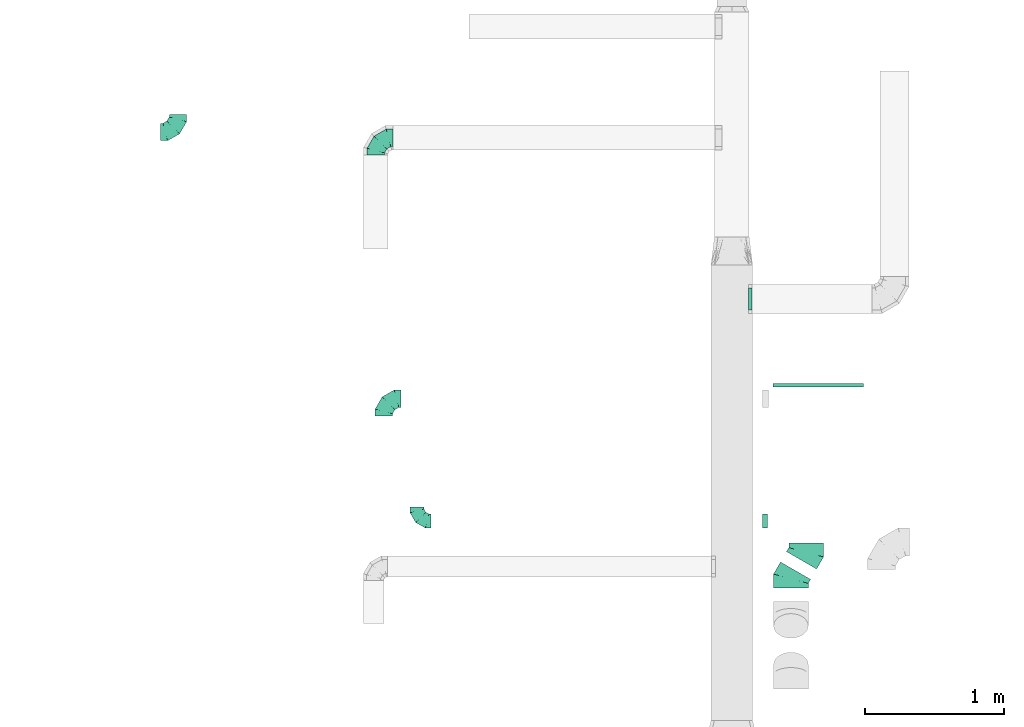
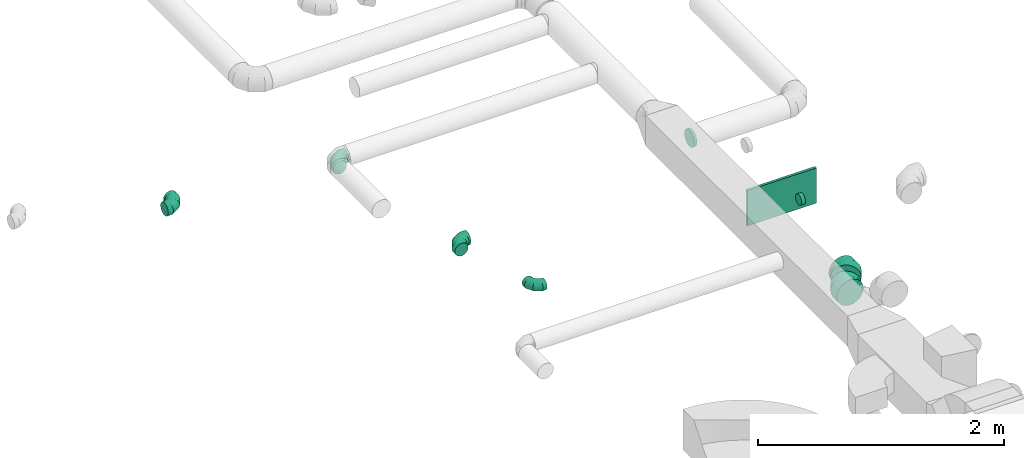
# One storey, part 31 of 62: 9 flow fittings.
"""IFC2X3 building model written with IfcOpenShell, lengths in millimetres."""

from ifc_helpers import new_model, entity, si_unit, converted_unit, derived_unit, direction, frame, origin, origin_2d_with_axis, place, context, subcontext, project, spatial, rectangle, extrude, faceted_brep, source, transform, mapped, material, type_object, type_shapes, element, save


model = new_model("IFC2X3")

# Units and contexts
model_context = context("Model", 3, precision=0.01, world=origin(), true_north=direction((6.12303176911189e-17, 1.0)))
body_context = subcontext(model_context, "Body", "Model", "MODEL_VIEW")
ifc_project = project(units=[si_unit("LENGTHUNIT", "METRE", prefix="MILLI"), si_unit("AREAUNIT", "SQUARE_METRE"), si_unit("VOLUMEUNIT", "CUBIC_METRE"), converted_unit("PLANEANGLEUNIT", "DEGREE", entity("IfcRatioMeasure", 0.0174532925199433), si_unit("PLANEANGLEUNIT", "RADIAN"), dimensions=[0, 0, 0, 0, 0, 0, 0]), si_unit("MASSUNIT", "GRAM", prefix="KILO"), derived_unit("MASSDENSITYUNIT", [(si_unit("MASSUNIT", "GRAM", prefix="KILO"), 1), (si_unit("LENGTHUNIT", "METRE"), -3)]), derived_unit("MOMENTOFINERTIAUNIT", [(si_unit("LENGTHUNIT", "METRE"), 4)]), si_unit("TIMEUNIT", "SECOND"), si_unit("FREQUENCYUNIT", "HERTZ"), si_unit("THERMODYNAMICTEMPERATUREUNIT", "DEGREE_CELSIUS"), derived_unit("THERMALTRANSMITTANCEUNIT", [(si_unit("MASSUNIT", "GRAM", prefix="KILO"), 1), (si_unit("THERMODYNAMICTEMPERATUREUNIT", "KELVIN"), -1), (si_unit("TIMEUNIT", "SECOND"), -3)]), derived_unit("VOLUMETRICFLOWRATEUNIT", [(si_unit("LENGTHUNIT", "METRE"), 3), (si_unit("TIMEUNIT", "SECOND"), -1)]), derived_unit("MASSFLOWRATEUNIT", [(si_unit("MASSUNIT", "GRAM", prefix="KILO"), 1), (si_unit("TIMEUNIT", "SECOND"), -1)]), derived_unit("ROTATIONALFREQUENCYUNIT", [(si_unit("TIMEUNIT", "SECOND"), -1)]), si_unit("ELECTRICCURRENTUNIT", "AMPERE"), si_unit("ELECTRICVOLTAGEUNIT", "VOLT"), si_unit("POWERUNIT", "WATT"), si_unit("FORCEUNIT", "NEWTON", prefix="KILO"), si_unit("ILLUMINANCEUNIT", "LUX"), si_unit("LUMINOUSFLUXUNIT", "LUMEN"), si_unit("LUMINOUSINTENSITYUNIT", "CANDELA"), derived_unit("USERDEFINED", [(si_unit("MASSUNIT", "GRAM", prefix="KILO"), -1), (si_unit("LENGTHUNIT", "METRE"), -2), (si_unit("TIMEUNIT", "SECOND"), 3), (si_unit("LUMINOUSFLUXUNIT", "LUMEN"), 1)]), derived_unit("LINEARVELOCITYUNIT", [(si_unit("LENGTHUNIT", "METRE"), 1), (si_unit("TIMEUNIT", "SECOND"), -1)]), si_unit("PRESSUREUNIT", "PASCAL"), derived_unit("USERDEFINED", [(si_unit("LENGTHUNIT", "METRE"), -2), (si_unit("MASSUNIT", "GRAM", prefix="KILO"), 1), (si_unit("TIMEUNIT", "SECOND"), -2)]), derived_unit("LINEARFORCEUNIT", [(si_unit("MASSUNIT", "GRAM", prefix="KILO"), 1), (si_unit("LENGTHUNIT", "METRE"), 1), (si_unit("TIMEUNIT", "SECOND"), -2), (si_unit("LENGTHUNIT", "METRE"), -1)]), derived_unit("PLANARFORCEUNIT", [(si_unit("MASSUNIT", "GRAM", prefix="KILO"), 1), (si_unit("LENGTHUNIT", "METRE"), 1), (si_unit("TIMEUNIT", "SECOND"), -2), (si_unit("LENGTHUNIT", "METRE"), -2)])], contexts=[model_context])

# Site, building, storey
site_placement = place(None, origin())
site = spatial("IfcSite", under=ifc_project, at=site_placement, CompositionType="ELEMENT")
building_placement = place(site_placement, origin())
building = spatial("IfcBuilding", under=site, at=building_placement, CompositionType="ELEMENT")
storey_placement = place(building_placement, frame((0.0, 0.0, 24000.0)))
storey = spatial("IfcBuildingStorey", under=building, at=storey_placement, CompositionType="ELEMENT", Elevation=24000.0)

# Flow fittings
ifc_material = material()
duct_fitting_type_1 = type_object("IfcDuctFittingType", PredefinedType="NOTDEFINED", material=ifc_material)
shared_shape_1 = source(origin(), body_context, "Body", "SweptSolid", [
    extrude(rectangle(XDim=24.9999999999999, YDim=650.0, at=origin_2d_with_axis()), frame((12.5, 0.0, -175.0)), (0.0, 0.0, 1.0), 350.0),
])
type_shapes(duct_fitting_type_1, [shared_shape_1])
flow_fitting_1_placement = place(storey_placement, frame((40717.62, 13747.53, 2775.0), z_axis=(0.0, 0.0, 1.0), x_axis=(0.0, 1.0, 0.0)))
element("IfcFlowFitting", 1, at=flow_fitting_1_placement, inside=storey, type_object=duct_fitting_type_1, material=ifc_material, context=body_context, shape_type="MappedRepresentation", body=[
    mapped(shared_shape_1, transform((0.0, 0.0, 0.0), scale=1.0)),
])
duct_fitting_type_2 = type_object("IfcDuctFittingType", PredefinedType="NOTDEFINED", material=ifc_material)
shared_shape_2 = source(origin(), body_context, "Body", "Brep", [
    faceted_brep([(-100.0, 0.0, -50.0), (-100.0, -12.94, -48.3), (-100.0, -25.0, -43.3), (-100.0, -35.36, -35.36), (-100.0, -43.3, -25.0), (-100.0, -48.3, -12.94), (-100.0, -50.0, 0.0), (-100.0, -48.3, 12.94), (-100.0, -43.3, 25.0), (-100.0, -35.36, 35.36), (-100.0, -25.0, 43.3), (-100.0, -12.94, 48.3), (-100.0, 0.0, 50.0), (-100.0, 12.94, 48.3), (-100.0, 25.0, 43.3), (-100.0, 35.36, 35.36), (-100.0, 43.3, 25.0), (-100.0, 48.3, 12.94), (-100.0, 50.0, 0.0), (-100.0, 48.3, -12.94), (-100.0, 43.3, -25.0), (-100.0, 35.36, -35.36), (-100.0, 25.0, -43.3), (-100.0, 12.94, -48.3), (-76.67, 12.94, 48.3), (-79.9, 25.0, 43.3), (-73.21, 0.0, 50.0), (-82.68, 35.36, 35.36), (-86.15, 48.3, 12.94), (-86.6, 50.0, 0.0), (-84.81, 43.3, 25.0), (-84.81, 43.3, -25.0), (-82.68, 35.36, -35.36), (-86.15, 48.3, -12.94), (-76.67, 12.94, -48.3), (-73.21, 0.0, -50.0), (-79.9, 25.0, -43.3), (-69.74, -12.94, -48.3), (-66.51, -25.0, -43.3), (-63.73, -35.36, -35.36), (-61.6, -43.3, -25.0), (-60.26, -48.3, -12.94), (-59.81, -50.0, 0.0), (-60.26, -48.3, 12.94), (-61.6, -43.3, 25.0), (-63.73, -35.36, 35.36), (-66.51, -25.0, 43.3), (-69.74, -12.94, 48.3), (-36.27, 36.27, 48.3), (-45.1, 45.1, 43.3), (-26.79, 26.79, 50.0), (-52.68, 52.68, 35.36), (-58.49, 58.49, 25.0), (-62.15, 62.15, 12.94), (-63.4, 63.4, 0.0), (-62.15, 62.15, -12.94), (-58.49, 58.49, -25.0), (-52.68, 52.68, -35.36), (-36.27, 36.27, -48.3), (-26.79, 26.79, -50.0), (-45.1, 45.1, -43.3), (-17.32, 17.32, -48.3), (-8.49, 8.49, -43.3), (-0.91, 0.91, -35.36), (4.9, -4.9, -25.0), (8.56, -8.56, -12.94), (9.81, -9.81, 0.0), (8.56, -8.56, 12.94), (4.9, -4.9, 25.0), (-0.91, 0.91, 35.36), (-8.49, 8.49, 43.3), (-17.32, 17.32, 48.3), (-12.94, 76.67, 48.3), (-25.0, 79.9, 43.3), (0.0, 73.21, 50.0), (-35.36, 82.68, 35.36), (-43.3, 84.81, 25.0), (-48.3, 86.15, 12.94), (-50.0, 86.6, 0.0), (-48.3, 86.15, -12.94), (-43.3, 84.81, -25.0), (-35.36, 82.68, -35.36), (-12.94, 76.67, -48.3), (0.0, 73.21, -50.0), (-25.0, 79.9, -43.3), (12.94, 69.74, -48.3), (25.0, 66.51, -43.3), (35.36, 63.73, -35.36), (43.3, 61.6, -25.0), (48.3, 60.26, -12.94), (50.0, 59.81, 0.0), (48.3, 60.26, 12.94), (43.3, 61.6, 25.0), (35.36, 63.73, 35.36), (25.0, 66.51, 43.3), (12.94, 69.74, 48.3), (-12.94, 100.0, -48.3), (-25.0, 100.0, -43.3), (-35.36, 100.0, -35.36), (-43.3, 100.0, -25.0), (-48.3, 100.0, -12.94), (-50.0, 100.0, 0.0), (-48.3, 100.0, 12.94), (-43.3, 100.0, 25.0), (-35.36, 100.0, 35.36), (-25.0, 100.0, 43.3), (-12.94, 100.0, 48.3), (0.0, 100.0, 50.0), (12.94, 100.0, 48.3), (25.0, 100.0, 43.3), (35.36, 100.0, 35.36), (43.3, 100.0, 25.0), (48.3, 100.0, 12.94), (50.0, 100.0, 0.0), (48.3, 100.0, -12.94), (43.3, 100.0, -25.0), (35.36, 100.0, -35.36), (25.0, 100.0, -43.3), (12.94, 100.0, -48.3), (0.0, 100.0, -50.0)], [[[0, 1, 2, 3, 4, 5, 6, 7, 8, 9, 10, 11, 12, 13, 14, 15, 16, 17, 18, 19, 20, 21, 22, 23]], [[24, 25, 14, 13]], [[26, 24, 13, 12]], [[14, 25, 27, 15]], [[28, 29, 18, 17]], [[30, 28, 17, 16]], [[15, 27, 30, 16]], [[20, 31, 32, 21]], [[33, 31, 20, 19]], [[18, 29, 33, 19]], [[34, 35, 0, 23]], [[36, 34, 23, 22]], [[32, 36, 22, 21]], [[2, 1, 37, 38]], [[3, 2, 38, 39]], [[0, 35, 37, 1]], [[5, 4, 40, 41]], [[6, 5, 41, 42]], [[3, 39, 40, 4]], [[6, 42, 43, 7]], [[7, 43, 44, 8]], [[8, 44, 45, 9]], [[10, 46, 47, 11]], [[11, 47, 26, 12]], [[10, 9, 45, 46]], [[48, 49, 25, 24]], [[50, 48, 24, 26]], [[27, 25, 49, 51]], [[52, 53, 28, 30]], [[51, 52, 30, 27]], [[29, 28, 53, 54]], [[55, 56, 31, 33]], [[54, 55, 33, 29]], [[57, 32, 31, 56]], [[58, 59, 35, 34]], [[60, 58, 34, 36]], [[57, 60, 36, 32]], [[37, 35, 59, 61]], [[38, 37, 61, 62]], [[39, 38, 62, 63]], [[41, 40, 64, 65]], [[42, 41, 65, 66]], [[63, 64, 40, 39]], [[43, 42, 66, 67]], [[44, 43, 67, 68]], [[68, 69, 45, 44]], [[46, 45, 69, 70]], [[47, 46, 70, 71]], [[26, 47, 71, 50]], [[72, 73, 49, 48]], [[74, 72, 48, 50]], [[51, 49, 73, 75]], [[76, 77, 53, 52]], [[75, 76, 52, 51]], [[54, 53, 77, 78]], [[79, 80, 56, 55]], [[78, 79, 55, 54]], [[81, 57, 56, 80]], [[82, 83, 59, 58]], [[84, 82, 58, 60]], [[81, 84, 60, 57]], [[61, 59, 83, 85]], [[62, 61, 85, 86]], [[63, 62, 86, 87]], [[65, 64, 88, 89]], [[66, 65, 89, 90]], [[87, 88, 64, 63]], [[67, 66, 90, 91]], [[68, 67, 91, 92]], [[92, 93, 69, 68]], [[70, 69, 93, 94]], [[71, 70, 94, 95]], [[50, 71, 95, 74]], [[96, 97, 98, 99, 100, 101, 102, 103, 104, 105, 106, 107, 108, 109, 110, 111, 112, 113, 114, 115, 116, 117, 118, 119]], [[72, 74, 107, 106]], [[73, 72, 106, 105]], [[75, 73, 105, 104]], [[77, 76, 103, 102]], [[78, 77, 102, 101]], [[75, 104, 103, 76]], [[78, 101, 100, 79]], [[79, 100, 99, 80]], [[80, 99, 98, 81]], [[96, 119, 83, 82]], [[97, 96, 82, 84]], [[84, 81, 98, 97]], [[83, 119, 118, 85]], [[85, 118, 117, 86]], [[86, 117, 116, 87]], [[88, 115, 114, 89]], [[89, 114, 113, 90]], [[87, 116, 115, 88]], [[91, 90, 113, 112]], [[92, 91, 112, 111]], [[93, 92, 111, 110]], [[95, 94, 109, 108]], [[74, 95, 108, 107]], [[110, 109, 94, 93]]]),
])
type_shapes(duct_fitting_type_2, [shared_shape_2])
flow_fitting_2_placement = place(storey_placement, frame((37828.89, 12781.82, 3475.0), z_axis=(0.0, 0.0, 1.0), x_axis=(0.0, -1.0, 0.0)))
element("IfcFlowFitting", 2, at=flow_fitting_2_placement, inside=storey, type_object=duct_fitting_type_2, material=ifc_material, context=body_context, shape_type="MappedRepresentation", body=[
    mapped(shared_shape_2, transform((0.0, 0.0, 0.0), scale=1.0)),
])
duct_fitting_type_3 = type_object("IfcDuctFittingType", PredefinedType="NOTDEFINED", material=ifc_material)
shared_shape_3 = source(origin(), body_context, "Body", "Brep", [
    faceted_brep([(-125.0, 0.0, -62.5), (-125.0, -16.18, -60.37), (-125.0, -31.25, -54.13), (-125.0, -44.19, -44.19), (-125.0, -54.13, -31.25), (-125.0, -60.37, -16.18), (-125.0, -62.5, 0.0), (-125.0, -60.37, 16.18), (-125.0, -54.13, 31.25), (-125.0, -44.19, 44.19), (-125.0, -31.25, 54.13), (-125.0, -16.18, 60.37), (-125.0, 0.0, 62.5), (-125.0, 16.18, 60.37), (-125.0, 31.25, 54.13), (-125.0, 44.19, 44.19), (-125.0, 54.13, 31.25), (-125.0, 60.37, 16.18), (-125.0, 62.5, 0.0), (-125.0, 60.37, -16.18), (-125.0, 54.13, -31.25), (-125.0, 44.19, -44.19), (-125.0, 31.25, -54.13), (-125.0, 16.18, -60.37), (-95.84, 16.18, 60.37), (-99.88, 31.25, 54.13), (-91.51, 0.0, 62.5), (-103.35, 44.19, 44.19), (-107.68, 60.37, 16.18), (-108.25, 62.5, 0.0), (-106.01, 54.13, 31.25), (-106.01, 54.13, -31.25), (-103.35, 44.19, -44.19), (-107.68, 60.37, -16.18), (-95.84, 16.18, -60.37), (-91.51, 0.0, -62.5), (-99.88, 31.25, -54.13), (-87.17, -16.18, -60.37), (-83.13, -31.25, -54.13), (-79.66, -44.19, -44.19), (-77.0, -54.13, -31.25), (-75.33, -60.37, -16.18), (-74.76, -62.5, 0.0), (-75.33, -60.37, 16.18), (-77.0, -54.13, 31.25), (-79.66, -44.19, 44.19), (-83.13, -31.25, 54.13), (-87.17, -16.18, 60.37), (-45.34, 45.34, 60.37), (-56.37, 56.37, 54.13), (-33.49, 33.49, 62.5), (-65.85, 65.85, 44.19), (-73.12, 73.12, 31.25), (-77.69, 77.69, 16.18), (-79.25, 79.25, 0.0), (-77.69, 77.69, -16.18), (-73.12, 73.12, -31.25), (-65.85, 65.85, -44.19), (-45.34, 45.34, -60.37), (-33.49, 33.49, -62.5), (-56.37, 56.37, -54.13), (-21.65, 21.65, -60.37), (-10.62, 10.62, -54.13), (-1.14, 1.14, -44.19), (6.13, -6.13, -31.25), (10.7, -10.7, -16.18), (12.26, -12.26, 0.0), (10.7, -10.7, 16.18), (6.13, -6.13, 31.25), (-1.14, 1.14, 44.19), (-10.62, 10.62, 54.13), (-21.65, 21.65, 60.37), (-16.18, 95.84, 60.37), (-31.25, 99.88, 54.13), (0.0, 91.51, 62.5), (-44.19, 103.35, 44.19), (-54.13, 106.01, 31.25), (-60.37, 107.68, 16.18), (-62.5, 108.25, 0.0), (-60.37, 107.68, -16.18), (-54.13, 106.01, -31.25), (-44.19, 103.35, -44.19), (-16.18, 95.84, -60.37), (0.0, 91.51, -62.5), (-31.25, 99.88, -54.13), (16.18, 87.17, -60.37), (31.25, 83.13, -54.13), (44.19, 79.66, -44.19), (54.13, 77.0, -31.25), (60.37, 75.33, -16.18), (62.5, 74.76, 0.0), (60.37, 75.33, 16.18), (54.13, 77.0, 31.25), (44.19, 79.66, 44.19), (31.25, 83.13, 54.13), (16.18, 87.17, 60.37), (-16.18, 125.0, -60.37), (-31.25, 125.0, -54.13), (-44.19, 125.0, -44.19), (-54.13, 125.0, -31.25), (-60.37, 125.0, -16.18), (-62.5, 125.0, 0.0), (-60.37, 125.0, 16.18), (-54.13, 125.0, 31.25), (-44.19, 125.0, 44.19), (-31.25, 125.0, 54.13), (-16.18, 125.0, 60.37), (0.0, 125.0, 62.5), (16.18, 125.0, 60.37), (31.25, 125.0, 54.13), (44.19, 125.0, 44.19), (54.13, 125.0, 31.25), (60.37, 125.0, 16.18), (62.5, 125.0, 0.0), (60.37, 125.0, -16.18), (54.13, 125.0, -31.25), (44.19, 125.0, -44.19), (31.25, 125.0, -54.13), (16.18, 125.0, -60.37), (0.0, 125.0, -62.5)], [[[0, 1, 2, 3, 4, 5, 6, 7, 8, 9, 10, 11, 12, 13, 14, 15, 16, 17, 18, 19, 20, 21, 22, 23]], [[24, 25, 14, 13]], [[26, 24, 13, 12]], [[14, 25, 27, 15]], [[28, 29, 18, 17]], [[30, 28, 17, 16]], [[15, 27, 30, 16]], [[20, 31, 32, 21]], [[33, 31, 20, 19]], [[18, 29, 33, 19]], [[34, 35, 0, 23]], [[36, 34, 23, 22]], [[21, 32, 36, 22]], [[1, 0, 35, 37]], [[2, 1, 37, 38]], [[38, 39, 3, 2]], [[5, 4, 40, 41]], [[6, 5, 41, 42]], [[39, 40, 4, 3]], [[6, 42, 43, 7]], [[7, 43, 44, 8]], [[45, 9, 8, 44]], [[9, 45, 46, 10]], [[10, 46, 47, 11]], [[26, 12, 11, 47]], [[48, 49, 25, 24]], [[50, 48, 24, 26]], [[27, 25, 49, 51]], [[52, 53, 28, 30]], [[51, 52, 30, 27]], [[29, 28, 53, 54]], [[55, 56, 31, 33]], [[54, 55, 33, 29]], [[57, 32, 31, 56]], [[58, 59, 35, 34]], [[60, 58, 34, 36]], [[57, 60, 36, 32]], [[37, 35, 59, 61]], [[38, 37, 61, 62]], [[39, 38, 62, 63]], [[41, 40, 64, 65]], [[42, 41, 65, 66]], [[63, 64, 40, 39]], [[43, 42, 66, 67]], [[44, 43, 67, 68]], [[68, 69, 45, 44]], [[46, 45, 69, 70]], [[47, 46, 70, 71]], [[26, 47, 71, 50]], [[72, 73, 49, 48]], [[74, 72, 48, 50]], [[51, 49, 73, 75]], [[76, 77, 53, 52]], [[75, 76, 52, 51]], [[54, 53, 77, 78]], [[79, 80, 56, 55]], [[78, 79, 55, 54]], [[81, 57, 56, 80]], [[82, 83, 59, 58]], [[84, 82, 58, 60]], [[81, 84, 60, 57]], [[61, 59, 83, 85]], [[62, 61, 85, 86]], [[63, 62, 86, 87]], [[65, 64, 88, 89]], [[66, 65, 89, 90]], [[87, 88, 64, 63]], [[67, 66, 90, 91]], [[68, 67, 91, 92]], [[92, 93, 69, 68]], [[70, 69, 93, 94]], [[71, 70, 94, 95]], [[50, 71, 95, 74]], [[96, 97, 98, 99, 100, 101, 102, 103, 104, 105, 106, 107, 108, 109, 110, 111, 112, 113, 114, 115, 116, 117, 118, 119]], [[72, 74, 107, 106]], [[73, 72, 106, 105]], [[75, 73, 105, 104]], [[77, 76, 103, 102]], [[78, 77, 102, 101]], [[75, 104, 103, 76]], [[78, 101, 100, 79]], [[79, 100, 99, 80]], [[80, 99, 98, 81]], [[96, 119, 83, 82]], [[97, 96, 82, 84]], [[84, 81, 98, 97]], [[83, 119, 118, 85]], [[85, 118, 117, 86]], [[116, 87, 86, 117]], [[88, 115, 114, 89]], [[89, 114, 113, 90]], [[115, 88, 87, 116]], [[91, 90, 113, 112]], [[92, 91, 112, 111]], [[111, 110, 93, 92]], [[95, 94, 109, 108]], [[74, 95, 108, 107]], [[110, 109, 94, 93]]]),
])
type_shapes(duct_fitting_type_3, [shared_shape_3])
flow_fitting_3_placement = place(storey_placement, frame((36108.05, 15581.99, 3200.0)))
element("IfcFlowFitting", 3, at=flow_fitting_3_placement, inside=storey, type_object=duct_fitting_type_3, material=ifc_material, context=body_context, shape_type="MappedRepresentation", body=[
    mapped(shared_shape_3, transform((0.0, 0.0, 0.0), scale=1.0)),
])
for number, where, z_axis, x_axis in (
    (4, (37532.21, 15540.09, 3170.0), (0.0, 0.0, 1.0), (-1.0, 0.0, 0.0)),
    (5, (37590.02, 13662.52, 3475.0), (0.0, 0.0, 1.0), (-1.0, 0.0, 0.0)),
):
    element("IfcFlowFitting", number, at=place(storey_placement, frame(where, z_axis=z_axis, x_axis=x_axis)), inside=storey, type_object=duct_fitting_type_3, material=ifc_material, context=body_context, shape_type="MappedRepresentation", body=[
        mapped(shared_shape_3, transform((0.0, 0.0, 0.0), scale=1.0)),
    ])
duct_fitting_type_4 = type_object("IfcDuctFittingType", PredefinedType="NOTDEFINED", material=ifc_material)
shared_shape_4 = source(origin(), body_context, "Body", "Brep", [
    faceted_brep([(20.0, 20.71, -77.27), (20.0, 40.0, -69.28), (20.0, 56.57, -56.57), (20.0, 69.28, -40.0), (20.0, 77.27, -20.71), (20.0, 80.0, 0.0), (20.0, 77.27, 20.71), (20.0, 69.28, 40.0), (20.0, 56.57, 56.57), (20.0, 40.0, 69.28), (20.0, 20.71, 77.27), (20.0, 0.0, 80.0), (20.0, -20.71, 77.27), (20.0, -40.0, 69.28), (20.0, -56.57, 56.57), (20.0, -69.28, 40.0), (20.0, -77.27, 20.71), (20.0, -80.0, 0.0), (20.0, -77.27, -20.71), (20.0, -69.28, -40.0), (20.0, -56.57, -56.57), (20.0, -40.0, -69.28), (20.0, -20.71, -77.27), (20.0, 0.0, -80.0), (0.0, 0.0, 80.0), (0.0, 20.71, 77.27), (-6.1, 20.71, 77.27), (-6.1, 0.0, 80.0), (0.0, 40.0, 69.28), (-6.1, 40.0, 69.28), (0.0, 56.57, 56.57), (-6.1, 56.57, 56.57), (0.0, 69.28, 40.0), (0.0, 77.27, 20.71), (-6.1, 77.27, 20.71), (-6.1, 69.28, 40.0), (0.0, 80.0, 0.0), (-6.1, 80.0, 0.0), (0.0, 77.27, -20.71), (-6.1, 77.27, -20.71), (0.0, 69.28, -40.0), (-6.1, 69.28, -40.0), (0.0, 56.57, -56.57), (-6.1, 56.57, -56.57), (0.0, 40.0, -69.28), (0.0, 20.71, -77.27), (-6.1, 20.71, -77.27), (-6.1, 40.0, -69.28), (0.0, 0.0, -80.0), (-6.1, 0.0, -80.0), (0.0, -20.71, -77.27), (-6.1, -20.71, -77.27), (0.0, -40.0, -69.28), (-6.1, -40.0, -69.28), (0.0, -56.57, -56.57), (-6.1, -56.57, -56.57), (0.0, -69.28, -40.0), (0.0, -77.27, -20.71), (-6.1, -77.27, -20.71), (-6.1, -69.28, -40.0), (0.0, -80.0, 0.0), (-6.1, -80.0, 0.0), (0.0, -77.27, 20.71), (-6.1, -77.27, 20.71), (0.0, -69.28, 40.0), (-6.1, -69.28, 40.0), (0.0, -56.57, 56.57), (-6.1, -56.57, 56.57), (0.0, -40.0, 69.28), (0.0, -20.71, 77.27), (-6.1, -20.71, 77.27), (-6.1, -40.0, 69.28)], [[[0, 1, 2, 3, 4, 5, 6, 7, 8, 9, 10, 11, 12, 13, 14, 15, 16, 17, 18, 19, 20, 21, 22, 23]], [[24, 11, 10, 25, 26, 27]], [[25, 10, 9, 28, 29, 26]], [[28, 9, 8, 30, 31, 29]], [[32, 7, 6, 33, 34, 35]], [[33, 6, 5, 36, 37, 34]], [[30, 8, 7, 32, 35, 31]], [[36, 5, 4, 38, 39, 37]], [[38, 4, 3, 40, 41, 39]], [[40, 3, 2, 42, 43, 41]], [[44, 1, 0, 45, 46, 47]], [[45, 0, 23, 48, 49, 46]], [[42, 2, 1, 44, 47, 43]], [[48, 23, 22, 50, 51, 49]], [[50, 22, 21, 52, 53, 51]], [[52, 21, 20, 54, 55, 53]], [[56, 19, 18, 57, 58, 59]], [[57, 18, 17, 60, 61, 58]], [[54, 20, 19, 56, 59, 55]], [[60, 17, 16, 62, 63, 61]], [[62, 16, 15, 64, 65, 63]], [[64, 15, 14, 66, 67, 65]], [[68, 13, 12, 69, 70, 71]], [[69, 12, 11, 24, 27, 70]], [[66, 14, 13, 68, 71, 67]], [[49, 51, 53, 55, 59, 58, 61, 63, 65, 67, 71, 70, 27, 26, 29, 31, 35, 34, 37, 39, 41, 43, 47, 46]]]),
])
type_shapes(duct_fitting_type_4, [shared_shape_4])
flow_fitting_4_placement = place(storey_placement, frame((40220.11, 14380.86, 3150.0), z_axis=(0.0, 0.0, -1.0), x_axis=(1.0, 0.0, 0.0)))
element("IfcFlowFitting", 6, at=flow_fitting_4_placement, inside=storey, type_object=duct_fitting_type_4, material=ifc_material, context=body_context, shape_type="MappedRepresentation", body=[
    mapped(shared_shape_4, transform((0.0, 0.0, 0.0), scale=1.0)),
])
duct_fitting_type_5 = type_object("IfcDuctFittingType", PredefinedType="NOTDEFINED", material=ifc_material)
shared_shape_5 = source(origin(), body_context, "Body", "Brep", [
    faceted_brep([(-66.99, 0.0, -125.0), (-66.99, -32.35, -120.74), (-66.99, -62.5, -108.25), (-66.99, -88.39, -88.39), (-66.99, -108.25, -62.5), (-66.99, -120.74, -32.35), (-66.99, -125.0, 0.0), (-66.99, -120.74, 32.35), (-66.99, -108.25, 62.5), (-66.99, -88.39, 88.39), (-66.99, -62.5, 108.25), (-66.99, -32.35, 120.74), (-66.99, 0.0, 125.0), (-66.99, 32.35, 120.74), (-66.99, 62.5, 108.25), (-66.99, 88.39, 88.39), (-66.99, 108.25, 62.5), (-66.99, 120.74, 32.35), (-66.99, 125.0, 0.0), (-66.99, 120.74, -32.35), (-66.99, 108.25, -62.5), (-66.99, 88.39, -88.39), (-66.99, 62.5, -108.25), (-66.99, 32.35, -120.74), (-8.67, 32.35, 120.74), (-16.75, 62.5, 108.25), (0.0, 0.0, 125.0), (-23.68, 88.39, 88.39), (-32.35, 120.74, 32.35), (-33.49, 125.0, 0.0), (-29.01, 108.25, 62.5), (-29.01, 108.25, -62.5), (-23.68, 88.39, -88.39), (-32.35, 120.74, -32.35), (-8.67, 32.35, -120.74), (0.0, 0.0, -125.0), (-16.75, 62.5, -108.25), (8.67, -32.35, -120.74), (16.75, -62.5, -108.25), (23.68, -88.39, -88.39), (29.01, -108.25, -62.5), (32.35, -120.74, -32.35), (33.49, -125.0, 0.0), (32.35, -120.74, 32.35), (29.01, -108.25, 62.5), (23.68, -88.39, 88.39), (16.75, -62.5, 108.25), (8.67, -32.35, 120.74), (58.01, 33.49, 125.0), (41.84, 61.51, 120.74), (26.76, 87.62, 108.25), (13.82, 110.04, 88.39), (3.89, 127.24, 62.5), (-2.36, 138.06, 32.35), (-4.49, 141.75, 0.0), (-2.36, 138.06, -32.35), (3.89, 127.24, -62.5), (13.82, 110.04, -88.39), (26.76, 87.62, -108.25), (41.84, 61.51, -120.74), (58.01, 33.49, -125.0), (74.19, 5.48, -120.74), (89.26, -20.63, -108.25), (102.21, -43.05, -88.39), (112.14, -60.26, -62.5), (118.38, -71.07, -32.35), (120.51, -74.76, 0.0), (118.38, -71.07, 32.35), (112.14, -60.26, 62.5), (102.21, -43.05, 88.39), (89.26, -20.63, 108.25), (74.19, 5.48, 120.74)], [[[0, 1, 2, 3, 4, 5, 6, 7, 8, 9, 10, 11, 12, 13, 14, 15, 16, 17, 18, 19, 20, 21, 22, 23]], [[24, 25, 14, 13]], [[26, 24, 13, 12]], [[14, 25, 27, 15]], [[28, 29, 18, 17]], [[30, 28, 17, 16]], [[15, 27, 30, 16]], [[20, 31, 32, 21]], [[33, 31, 20, 19]], [[18, 29, 33, 19]], [[34, 35, 0, 23]], [[36, 34, 23, 22]], [[21, 32, 36, 22]], [[1, 0, 35, 37]], [[2, 1, 37, 38]], [[38, 39, 3, 2]], [[5, 4, 40, 41]], [[6, 5, 41, 42]], [[39, 40, 4, 3]], [[6, 42, 43, 7]], [[7, 43, 44, 8]], [[8, 44, 45, 9]], [[9, 45, 46, 10]], [[10, 46, 47, 11]], [[26, 12, 11, 47]], [[24, 26, 48, 49]], [[25, 24, 49, 50]], [[27, 25, 50, 51]], [[28, 30, 52, 53]], [[29, 28, 53, 54]], [[27, 51, 52, 30]], [[29, 54, 55, 33]], [[33, 55, 56, 31]], [[31, 56, 57, 32]], [[36, 58, 59, 34]], [[34, 59, 60, 35]], [[36, 32, 57, 58]], [[35, 60, 61, 37]], [[37, 61, 62, 38]], [[63, 39, 38, 62]], [[40, 64, 65, 41]], [[41, 65, 66, 42]], [[64, 40, 39, 63]], [[43, 42, 66, 67]], [[44, 43, 67, 68]], [[68, 69, 45, 44]], [[47, 46, 70, 71]], [[26, 47, 71, 48]], [[69, 70, 46, 45]], [[59, 58, 57, 56, 55, 54, 53, 52, 51, 50, 49, 48, 71, 70, 69, 68, 67, 66, 65, 64, 63, 62, 61, 60]]]),
])
type_shapes(duct_fitting_type_5, [shared_shape_5])
for number, where, z_axis, x_axis in (
    (7, (40520.63, 12366.34, 2775.0), (0.0, 0.0, 1.0), (-0.500000000000005, -0.866025403784436, 0.0)),
    (8, (40630.63, 12556.86, 2775.0), (0.0, 0.0, 1.0), (0.500000000000073, 0.866025403784397, 0.0)),
):
    element("IfcFlowFitting", number, at=place(storey_placement, frame(where, z_axis=z_axis, x_axis=x_axis)), inside=storey, type_object=duct_fitting_type_5, material=ifc_material, context=body_context, shape_type="MappedRepresentation", body=[
        mapped(shared_shape_5, transform((0.0, 0.0, 0.0), scale=1.0)),
    ])
duct_fitting_type_6 = type_object("IfcDuctFittingType", PredefinedType="NOTDEFINED", material=ifc_material)
shared_shape_6 = source(origin(), body_context, "Body", "Brep", [
    faceted_brep([(20.0, 12.94, -48.3), (20.0, 25.0, -43.3), (20.0, 35.36, -35.36), (20.0, 43.3, -25.0), (20.0, 48.3, -12.94), (20.0, 50.0, 0.0), (20.0, 48.3, 12.94), (20.0, 43.3, 25.0), (20.0, 35.36, 35.36), (20.0, 25.0, 43.3), (20.0, 12.94, 48.3), (20.0, 0.0, 50.0), (20.0, -12.94, 48.3), (20.0, -25.0, 43.3), (20.0, -35.36, 35.36), (20.0, -43.3, 25.0), (20.0, -48.3, 12.94), (20.0, -50.0, 0.0), (20.0, -48.3, -12.94), (20.0, -43.3, -25.0), (20.0, -35.36, -35.36), (20.0, -25.0, -43.3), (20.0, -12.94, -48.3), (20.0, 0.0, -50.0), (0.0, 0.0, 50.0), (0.0, 12.94, 48.3), (-16.53, 12.94, 48.3), (-16.53, 0.0, 50.0), (0.0, 25.0, 43.3), (-16.53, 25.0, 43.3), (0.0, 35.36, 35.36), (-16.53, 35.36, 35.36), (0.0, 43.3, 25.0), (0.0, 48.3, 12.94), (-16.53, 48.3, 12.94), (-16.53, 43.3, 25.0), (0.0, 50.0, 0.0), (-16.53, 50.0, 0.0), (0.0, 48.3, -12.94), (-16.53, 48.3, -12.94), (0.0, 43.3, -25.0), (-16.53, 43.3, -25.0), (0.0, 35.36, -35.36), (-16.53, 35.36, -35.36), (0.0, 25.0, -43.3), (0.0, 12.94, -48.3), (-16.53, 12.94, -48.3), (-16.53, 25.0, -43.3), (0.0, 0.0, -50.0), (-16.53, 0.0, -50.0), (0.0, -12.94, -48.3), (-16.53, -12.94, -48.3), (0.0, -25.0, -43.3), (-16.53, -25.0, -43.3), (0.0, -35.36, -35.36), (-16.53, -35.36, -35.36), (0.0, -43.3, -25.0), (0.0, -48.3, -12.94), (-16.53, -48.3, -12.94), (-16.53, -43.3, -25.0), (0.0, -50.0, 0.0), (-16.53, -50.0, 0.0), (0.0, -48.3, 12.94), (-16.53, -48.3, 12.94), (0.0, -43.3, 25.0), (-16.53, -43.3, 25.0), (0.0, -35.36, 35.36), (-16.53, -35.36, 35.36), (0.0, -25.0, 43.3), (0.0, -12.94, 48.3), (-16.53, -12.94, 48.3), (-16.53, -25.0, 43.3)], [[[0, 1, 2, 3, 4, 5, 6, 7, 8, 9, 10, 11, 12, 13, 14, 15, 16, 17, 18, 19, 20, 21, 22, 23]], [[24, 11, 10, 25, 26, 27]], [[25, 10, 9, 28, 29, 26]], [[28, 9, 8, 30, 31, 29]], [[32, 7, 6, 33, 34, 35]], [[33, 6, 5, 36, 37, 34]], [[30, 8, 7, 32, 35, 31]], [[36, 5, 4, 38, 39, 37]], [[38, 4, 3, 40, 41, 39]], [[40, 3, 2, 42, 43, 41]], [[44, 1, 0, 45, 46, 47]], [[45, 0, 23, 48, 49, 46]], [[42, 2, 1, 44, 47, 43]], [[48, 23, 22, 50, 51, 49]], [[50, 22, 21, 52, 53, 51]], [[52, 21, 20, 54, 55, 53]], [[56, 19, 18, 57, 58, 59]], [[57, 18, 17, 60, 61, 58]], [[54, 20, 19, 56, 59, 55]], [[60, 17, 16, 62, 63, 61]], [[62, 16, 15, 64, 65, 63]], [[64, 15, 14, 66, 67, 65]], [[68, 13, 12, 69, 70, 71]], [[69, 12, 11, 24, 27, 70]], [[66, 14, 13, 68, 71, 67]], [[49, 51, 53, 55, 59, 58, 61, 63, 65, 67, 71, 70, 27, 26, 29, 31, 35, 34, 37, 39, 41, 43, 47, 46]]]),
])
type_shapes(duct_fitting_type_6, [shared_shape_6])
flow_fitting_5_placement = place(storey_placement, frame((40335.63, 12781.82, 3475.0), z_axis=(0.0, 0.0, -1.0), x_axis=(-1.0, 0.0, 0.0)))
element("IfcFlowFitting", 9, at=flow_fitting_5_placement, inside=storey, type_object=duct_fitting_type_6, material=ifc_material, context=body_context, shape_type="MappedRepresentation", body=[
    mapped(shared_shape_6, transform((0.0, 0.0, 0.0), scale=1.0)),
])

save(model, "model.ifc")
